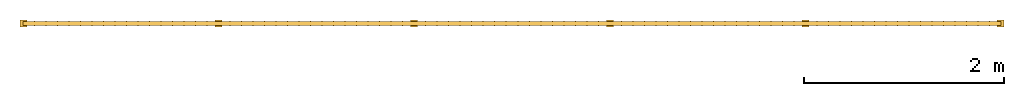
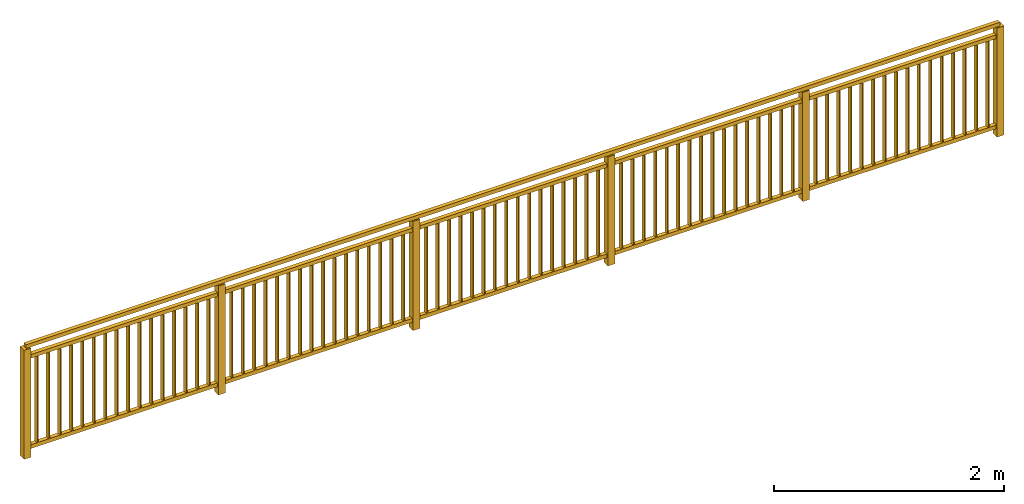
# Not in any storey: 1 railing.
"""IFC4 model written with IfcOpenShell, lengths in metres."""

from ifc_helpers import new_model, entity, si_unit, converted_unit, derived_unit, direction, frame, frame_2d, origin, place, context, subcontext, project, spatial, rectangle, extrude, material, element, save


model = new_model("IFC4")

# Units and contexts
model_context = context("Model", 3, precision=1e-05, world=origin(), true_north=direction((6.12303176911189e-17, 1.0)))
body_context = subcontext(model_context, "Body", "Model", "MODEL_VIEW")
ifc_project = project(units=[si_unit("LENGTHUNIT", "METRE"), si_unit("AREAUNIT", "SQUARE_METRE"), si_unit("VOLUMEUNIT", "CUBIC_METRE"), converted_unit("PLANEANGLEUNIT", "DEGREE", entity("IfcRatioMeasure", 0.0174532925199433), si_unit("PLANEANGLEUNIT", "RADIAN"), dimensions=[0, 0, 0, 0, 0, 0, 0]), si_unit("MASSUNIT", "GRAM", prefix="KILO"), derived_unit("MASSDENSITYUNIT", [(si_unit("MASSUNIT", "GRAM", prefix="KILO"), 1), (si_unit("LENGTHUNIT", "METRE"), -3)]), derived_unit("MOMENTOFINERTIAUNIT", [(si_unit("LENGTHUNIT", "METRE"), 4)]), si_unit("TIMEUNIT", "SECOND"), si_unit("FREQUENCYUNIT", "HERTZ"), si_unit("THERMODYNAMICTEMPERATUREUNIT", "DEGREE_CELSIUS"), derived_unit("THERMALTRANSMITTANCEUNIT", [(si_unit("MASSUNIT", "GRAM", prefix="KILO"), 1), (si_unit("THERMODYNAMICTEMPERATUREUNIT", "KELVIN"), -1), (si_unit("TIMEUNIT", "SECOND"), -3)]), derived_unit("VOLUMETRICFLOWRATEUNIT", [(si_unit("LENGTHUNIT", "METRE"), 3), (si_unit("TIMEUNIT", "SECOND"), -1)]), si_unit("ELECTRICCURRENTUNIT", "AMPERE"), si_unit("ELECTRICVOLTAGEUNIT", "VOLT"), si_unit("POWERUNIT", "WATT"), si_unit("FORCEUNIT", "NEWTON", prefix="KILO"), si_unit("ILLUMINANCEUNIT", "LUX"), si_unit("LUMINOUSFLUXUNIT", "LUMEN"), si_unit("LUMINOUSINTENSITYUNIT", "CANDELA"), derived_unit("USERDEFINED", [(si_unit("MASSUNIT", "GRAM", prefix="KILO"), -1), (si_unit("LENGTHUNIT", "METRE"), -2), (si_unit("TIMEUNIT", "SECOND"), 3), (si_unit("LUMINOUSFLUXUNIT", "LUMEN"), 1)]), derived_unit("LINEARVELOCITYUNIT", [(si_unit("LENGTHUNIT", "METRE"), 1), (si_unit("TIMEUNIT", "SECOND"), -1)]), si_unit("PRESSUREUNIT", "PASCAL"), derived_unit("USERDEFINED", [(si_unit("LENGTHUNIT", "METRE"), -2), (si_unit("MASSUNIT", "GRAM", prefix="KILO"), 1), (si_unit("TIMEUNIT", "SECOND"), -2)]), derived_unit("LINEARFORCEUNIT", [(si_unit("MASSUNIT", "GRAM", prefix="KILO"), 1), (si_unit("LENGTHUNIT", "METRE"), 1), (si_unit("TIMEUNIT", "SECOND"), -2), (si_unit("LENGTHUNIT", "METRE"), -1)]), derived_unit("PLANARFORCEUNIT", [(si_unit("MASSUNIT", "GRAM", prefix="KILO"), 1), (si_unit("LENGTHUNIT", "METRE"), 1), (si_unit("TIMEUNIT", "SECOND"), -2), (si_unit("LENGTHUNIT", "METRE"), -2)])], contexts=[model_context])

# Site
site_placement = place(None, origin())
site = spatial("IfcSite", under=ifc_project, at=site_placement, CompositionType="ELEMENT")

# Railing
ifc_material = material(Name="Kunststoff - grau 70-70-70", Category="Kunststoff")
railing_placement = place(site_placement, frame((-2.35917445388067, -3.01742114403174, 0.0)))
element("IfcRailing", 1, at=railing_placement, inside=site, material=ifc_material, PredefinedType="NOTDEFINED", context=body_context, shape_type="SweptSolid", body=[
    extrude(rectangle(XDim=0.00999999999999989, YDim=0.05, at=frame_2d((1.08290112987852e-15, -2.70616862252382e-16), x_axis=(1.0, 0.0))), frame((9.71470588235294, 0.0350000000000007, 0.12)), (0.0, 0.0, 1.0), 0.92),
    extrude(rectangle(XDim=0.00999999999999989, YDim=0.05, at=frame_2d((0.0, 2.70616862252382e-16), x_axis=(1.0, 0.0))), frame((9.59941176470589, 0.0350000000000012, 0.12)), (0.0, 0.0, 1.0), 0.92),
    extrude(rectangle(XDim=0.00999999999999989, YDim=0.05, at=frame_2d((-1.08290112987852e-15, -2.70616862252382e-16), x_axis=(1.0, 0.0))), frame((9.48411764705883, 0.0350000000000018, 0.12)), (0.0, 0.0, 1.0), 0.92),
    extrude(rectangle(XDim=0.00999999999999989, YDim=0.05, at=frame_2d((-1.08290112987852e-15, 2.70616862252382e-16), x_axis=(1.0, 0.0))), frame((9.36882352941177, 0.0350000000000023, 0.12)), (0.0, 0.0, 1.0), 0.92),
    extrude(rectangle(XDim=0.00999999999999989, YDim=0.05, at=frame_2d((0.0, -2.70616862252382e-16), x_axis=(1.0, 0.0))), frame((9.25352941176471, 0.0350000000000029, 0.12)), (0.0, 0.0, 1.0), 0.92),
    extrude(rectangle(XDim=0.00999999999999989, YDim=0.05, at=frame_2d((0.0, 2.70616862252382e-16), x_axis=(1.0, 0.0))), frame((9.13823529411765, 0.0350000000000034, 0.12)), (0.0, 0.0, 1.0), 0.92),
    extrude(rectangle(XDim=0.00999999999999989, YDim=0.05, at=frame_2d((1.08290112987852e-15, -2.70616862252382e-16), x_axis=(1.0, 0.0))), frame((9.02294117647059, 0.035000000000004, 0.12)), (0.0, 0.0, 1.0), 0.92),
    extrude(rectangle(XDim=0.00999999999999989, YDim=0.05, at=frame_2d((0.0, 2.70616862252382e-16), x_axis=(1.0, 0.0))), frame((8.90764705882353, 0.0350000000000045, 0.12)), (0.0, 0.0, 1.0), 0.92),
    extrude(rectangle(XDim=0.00999999999999989, YDim=0.05, at=frame_2d((0.0, -2.70616862252382e-16), x_axis=(1.0, 0.0))), frame((8.79235294117647, 0.035000000000005, 0.12)), (0.0, 0.0, 1.0), 0.92),
    extrude(rectangle(XDim=0.00999999999999989, YDim=0.05, at=frame_2d((0.0, -2.70616862252382e-16), x_axis=(1.0, 0.0))), frame((8.67705882352941, 0.035000000000005, 0.12)), (0.0, 0.0, 1.0), 0.92),
    extrude(rectangle(XDim=0.00999999999999989, YDim=0.05, at=frame_2d((0.0, 2.70616862252382e-16), x_axis=(1.0, 0.0))), frame((8.56176470588236, 0.0350000000000056, 0.12)), (0.0, 0.0, 1.0), 0.92),
    extrude(rectangle(XDim=0.00999999999999989, YDim=0.05, at=frame_2d((0.0, -2.70616862252382e-16), x_axis=(1.0, 0.0))), frame((8.4464705882353, 0.0350000000000061, 0.12)), (0.0, 0.0, 1.0), 0.92),
    extrude(rectangle(XDim=0.00999999999999989, YDim=0.05, at=frame_2d((0.0, 2.70616862252382e-16), x_axis=(1.0, 0.0))), frame((8.33117647058824, 0.0350000000000067, 0.12)), (0.0, 0.0, 1.0), 0.92),
    extrude(rectangle(XDim=0.00999999999999989, YDim=0.05, at=frame_2d((0.0, -2.70616862252382e-16), x_axis=(1.0, 0.0))), frame((8.21588235294118, 0.0350000000000072, 0.12)), (0.0, 0.0, 1.0), 0.92),
    extrude(rectangle(XDim=0.00999999999999989, YDim=0.05, at=frame_2d((0.0, 2.70616862252382e-16), x_axis=(1.0, 0.0))), frame((8.10058823529412, 0.0350000000000077, 0.12)), (0.0, 0.0, 1.0), 0.92),
    extrude(rectangle(XDim=0.00999999999999989, YDim=0.05, at=frame_2d((0.0, -2.70616862252382e-16), x_axis=(1.0, 0.0))), frame((7.98529411764706, 0.0350000000000083, 0.12)), (0.0, 0.0, 1.0), 0.92),
    extrude(rectangle(XDim=0.0699999999999992, YDim=0.0699999999999998, at=frame_2d((0.0, 2.70616862252382e-16), x_axis=(1.0, 0.0))), frame((7.87, 0.0350000000000088, 0.0)), (0.0, 0.0, 1.0), 1.16),
    extrude(rectangle(XDim=0.00999999999999989, YDim=0.05, at=frame_2d((0.0, -2.70616862252382e-16), x_axis=(1.0, 0.0))), frame((7.75470588235294, 0.0350000000000094, 0.12)), (0.0, 0.0, 1.0), 0.92),
    extrude(rectangle(XDim=0.00999999999999989, YDim=0.05, at=frame_2d((0.0, -2.70616862252382e-16), x_axis=(1.0, 0.0))), frame((7.63941176470589, 0.0350000000000094, 0.12)), (0.0, 0.0, 1.0), 0.92),
    extrude(rectangle(XDim=0.00999999999999989, YDim=0.05, at=frame_2d((0.0, 2.70616862252382e-16), x_axis=(1.0, 0.0))), frame((7.52411764705883, 0.0350000000000099, 0.12)), (0.0, 0.0, 1.0), 0.92),
    extrude(rectangle(XDim=0.00999999999999989, YDim=0.05, at=frame_2d((0.0, -2.70616862252382e-16), x_axis=(1.0, 0.0))), frame((7.40882352941177, 0.0350000000000105, 0.12)), (0.0, 0.0, 1.0), 0.92),
    extrude(rectangle(XDim=0.00999999999999989, YDim=0.05, at=frame_2d((0.0, 2.70616862252382e-16), x_axis=(1.0, 0.0))), frame((7.29352941176471, 0.035000000000011, 0.12)), (0.0, 0.0, 1.0), 0.92),
    extrude(rectangle(XDim=0.00999999999999989, YDim=0.05, at=frame_2d((0.0, -2.70616862252382e-16), x_axis=(1.0, 0.0))), frame((7.17823529411765, 0.0350000000000115, 0.12)), (0.0, 0.0, 1.0), 0.92),
    extrude(rectangle(XDim=0.00999999999999989, YDim=0.05, at=frame_2d((0.0, 2.70616862252382e-16), x_axis=(1.0, 0.0))), frame((7.06294117647059, 0.0350000000000121, 0.12)), (0.0, 0.0, 1.0), 0.92),
    extrude(rectangle(XDim=0.00999999999999989, YDim=0.05, at=frame_2d((0.0, -2.70616862252382e-16), x_axis=(1.0, 0.0))), frame((6.94764705882353, 0.0350000000000126, 0.12)), (0.0, 0.0, 1.0), 0.92),
    extrude(rectangle(XDim=0.00999999999999989, YDim=0.05, at=frame_2d((0.0, 2.70616862252382e-16), x_axis=(1.0, 0.0))), frame((6.83235294117647, 0.0350000000000132, 0.12)), (0.0, 0.0, 1.0), 0.92),
    extrude(rectangle(XDim=0.00999999999999989, YDim=0.05, at=frame_2d((0.0, -2.70616862252382e-16), x_axis=(1.0, 0.0))), frame((6.71705882352941, 0.0350000000000137, 0.12)), (0.0, 0.0, 1.0), 0.92),
    extrude(rectangle(XDim=0.00999999999999989, YDim=0.05, at=frame_2d((0.0, -2.70616862252382e-16), x_axis=(1.0, 0.0))), frame((6.60176470588236, 0.0350000000000137, 0.12)), (0.0, 0.0, 1.0), 0.92),
    extrude(rectangle(XDim=0.00999999999999989, YDim=0.05, at=frame_2d((0.0, 2.70616862252382e-16), x_axis=(1.0, 0.0))), frame((6.4864705882353, 0.0350000000000142, 0.12)), (0.0, 0.0, 1.0), 0.92),
    extrude(rectangle(XDim=0.00999999999999989, YDim=0.05, at=frame_2d((0.0, -2.70616862252382e-16), x_axis=(1.0, 0.0))), frame((6.37117647058824, 0.0350000000000148, 0.12)), (0.0, 0.0, 1.0), 0.92),
    extrude(rectangle(XDim=0.00999999999999989, YDim=0.05, at=frame_2d((0.0, 2.70616862252382e-16), x_axis=(1.0, 0.0))), frame((6.25588235294118, 0.0350000000000153, 0.12)), (0.0, 0.0, 1.0), 0.92),
    extrude(rectangle(XDim=0.00999999999999989, YDim=0.05, at=frame_2d((0.0, -2.70616862252382e-16), x_axis=(1.0, 0.0))), frame((6.14058823529412, 0.0350000000000159, 0.12)), (0.0, 0.0, 1.0), 0.92),
    extrude(rectangle(XDim=0.00999999999999989, YDim=0.05, at=frame_2d((0.0, 2.70616862252382e-16), x_axis=(1.0, 0.0))), frame((6.02529411764706, 0.0350000000000164, 0.12)), (0.0, 0.0, 1.0), 0.92),
    extrude(rectangle(XDim=0.0700000000000009, YDim=0.0699999999999998, at=frame_2d((-2.70616862252382e-16, -2.70616862252382e-16), x_axis=(1.0, 0.0))), frame((5.91, 0.0350000000000175, 0.0)), (0.0, 0.0, 1.0), 1.16),
    extrude(rectangle(XDim=0.00999999999999989, YDim=0.05, at=frame_2d((0.0, 2.70616862252382e-16), x_axis=(1.0, 0.0))), frame((5.79470588235294, 0.0350000000000175, 0.12)), (0.0, 0.0, 1.0), 0.92),
    extrude(rectangle(XDim=0.00999999999999989, YDim=0.05, at=frame_2d((0.0, -2.70616862252382e-16), x_axis=(1.0, 0.0))), frame((5.67941176470589, 0.035000000000018, 0.12)), (0.0, 0.0, 1.0), 0.92),
    extrude(rectangle(XDim=0.00999999999999989, YDim=0.05, at=frame_2d((0.0, -2.70616862252382e-16), x_axis=(1.0, 0.0))), frame((5.56411764705883, 0.035000000000018, 0.12)), (0.0, 0.0, 1.0), 0.92),
    extrude(rectangle(XDim=0.00999999999999989, YDim=0.05, at=frame_2d((0.0, 2.70616862252382e-16), x_axis=(1.0, 0.0))), frame((5.44882352941177, 0.0350000000000186, 0.12)), (0.0, 0.0, 1.0), 0.92),
    extrude(rectangle(XDim=0.00999999999999989, YDim=0.05, at=frame_2d((0.0, -2.70616862252382e-16), x_axis=(1.0, 0.0))), frame((5.33352941176471, 0.0350000000000191, 0.12)), (0.0, 0.0, 1.0), 0.92),
    extrude(rectangle(XDim=0.00999999999999989, YDim=0.05, at=frame_2d((0.0, 2.70616862252382e-16), x_axis=(1.0, 0.0))), frame((5.21823529411765, 0.0350000000000197, 0.12)), (0.0, 0.0, 1.0), 0.92),
    extrude(rectangle(XDim=0.00999999999999989, YDim=0.05, at=frame_2d((0.0, -2.70616862252382e-16), x_axis=(1.0, 0.0))), frame((5.10294117647059, 0.0350000000000202, 0.12)), (0.0, 0.0, 1.0), 0.92),
    extrude(rectangle(XDim=0.00999999999999989, YDim=0.05, at=frame_2d((0.0, 2.70616862252382e-16), x_axis=(1.0, 0.0))), frame((4.98764705882353, 0.0350000000000207, 0.12)), (0.0, 0.0, 1.0), 0.92),
    extrude(rectangle(XDim=0.00999999999999989, YDim=0.05, at=frame_2d((0.0, -2.70616862252382e-16), x_axis=(1.0, 0.0))), frame((4.87235294117647, 0.0350000000000213, 0.12)), (0.0, 0.0, 1.0), 0.92),
    extrude(rectangle(XDim=0.0100000000000002, YDim=0.05, at=frame_2d((-1.35308431126191e-16, 2.70616862252382e-16), x_axis=(1.0, 0.0))), frame((4.75705882352941, 0.0350000000000218, 0.12)), (0.0, 0.0, 1.0), 0.92),
    extrude(rectangle(XDim=0.0100000000000002, YDim=0.05, at=frame_2d((-1.35742111995185e-16, -2.70616862252382e-16), x_axis=(1.0, 0.0))), frame((4.64176470588236, 0.0350000000000224, 0.12)), (0.0, 0.0, 1.0), 0.92),
    extrude(rectangle(XDim=0.0100000000000002, YDim=0.05, at=frame_2d((-1.35742111995185e-16, -2.70616862252382e-16), x_axis=(1.0, 0.0))), frame((4.5264705882353, 0.0350000000000224, 0.12)), (0.0, 0.0, 1.0), 0.92),
    extrude(rectangle(XDim=0.0100000000000002, YDim=0.05, at=frame_2d((-1.35308431126191e-16, 2.70616862252382e-16), x_axis=(1.0, 0.0))), frame((4.41117647058824, 0.0350000000000229, 0.12)), (0.0, 0.0, 1.0), 0.92),
    extrude(rectangle(XDim=0.0100000000000002, YDim=0.05, at=frame_2d((1.35742111995185e-16, -2.70616862252382e-16), x_axis=(1.0, 0.0))), frame((4.29588235294118, 0.0350000000000235, 0.12)), (0.0, 0.0, 1.0), 0.92),
    extrude(rectangle(XDim=0.0100000000000002, YDim=0.05, at=frame_2d((-1.35308431126191e-16, 2.70616862252382e-16), x_axis=(1.0, 0.0))), frame((4.18058823529412, 0.035000000000024, 0.12)), (0.0, 0.0, 1.0), 0.92),
    extrude(rectangle(XDim=0.0100000000000002, YDim=0.05, at=frame_2d((-1.35742111995185e-16, -2.70616862252382e-16), x_axis=(1.0, 0.0))), frame((4.06529411764706, 0.0350000000000245, 0.12)), (0.0, 0.0, 1.0), 0.92),
    extrude(rectangle(XDim=0.0699999999999995, YDim=0.0699999999999998, at=frame_2d((1.35308431126191e-16, 2.70616862252382e-16), x_axis=(1.0, 0.0))), frame((3.95, 0.0350000000000251, 0.0)), (0.0, 0.0, 1.0), 1.16),
    extrude(rectangle(XDim=0.0100000000000002, YDim=0.05, at=frame_2d((-1.35742111995185e-16, -2.70616862252382e-16), x_axis=(1.0, 0.0))), frame((3.83470588235294, 0.0350000000000256, 0.12)), (0.0, 0.0, 1.0), 0.92),
    extrude(rectangle(XDim=0.0100000000000002, YDim=0.05, at=frame_2d((-1.35308431126191e-16, 2.70616862252382e-16), x_axis=(1.0, 0.0))), frame((3.71941176470588, 0.0350000000000262, 0.12)), (0.0, 0.0, 1.0), 0.92),
    extrude(rectangle(XDim=0.0100000000000002, YDim=0.05, at=frame_2d((-1.35742111995185e-16, -2.70616862252382e-16), x_axis=(1.0, 0.0))), frame((3.60411764705882, 0.0350000000000267, 0.12)), (0.0, 0.0, 1.0), 0.92),
    extrude(rectangle(XDim=0.00999999999999989, YDim=0.05, at=frame_2d((0.0, -2.70616862252382e-16), x_axis=(1.0, 0.0))), frame((3.48882352941177, 0.0350000000000267, 0.12)), (0.0, 0.0, 1.0), 0.92),
    extrude(rectangle(XDim=0.00999999999999989, YDim=0.05, at=frame_2d((0.0, 2.70616862252382e-16), x_axis=(1.0, 0.0))), frame((3.37352941176471, 0.0350000000000272, 0.12)), (0.0, 0.0, 1.0), 0.92),
    extrude(rectangle(XDim=0.00999999999999989, YDim=0.05, at=frame_2d((1.35742111995185e-16, -2.70616862252382e-16), x_axis=(1.0, 0.0))), frame((3.25823529411765, 0.0350000000000278, 0.12)), (0.0, 0.0, 1.0), 0.92),
    extrude(rectangle(XDim=0.00999999999999989, YDim=0.05, at=frame_2d((0.0, 2.70616862252382e-16), x_axis=(1.0, 0.0))), frame((3.14294117647059, 0.0350000000000283, 0.12)), (0.0, 0.0, 1.0), 0.92),
    extrude(rectangle(XDim=0.00999999999999989, YDim=0.05, at=frame_2d((0.0, -2.70616862252382e-16), x_axis=(1.0, 0.0))), frame((3.02764705882353, 0.0350000000000289, 0.12)), (0.0, 0.0, 1.0), 0.92),
    extrude(rectangle(XDim=0.00999999999999996, YDim=0.05, at=frame_2d((-3.38271077815477e-17, 2.70616862252382e-16), x_axis=(1.0, 0.0))), frame((2.91235294117647, 0.0350000000000294, 0.12)), (0.0, 0.0, 1.0), 0.92),
    extrude(rectangle(XDim=0.00999999999999996, YDim=0.05, at=frame_2d((-3.38271077815477e-17, -2.70616862252382e-16), x_axis=(1.0, 0.0))), frame((2.79705882352941, 0.0350000000000299, 0.12)), (0.0, 0.0, 1.0), 0.92),
    extrude(rectangle(XDim=0.00999999999999996, YDim=0.05, at=frame_2d((-3.38271077815477e-17, 2.70616862252382e-16), x_axis=(1.0, 0.0))), frame((2.68176470588235, 0.0350000000000305, 0.12)), (0.0, 0.0, 1.0), 0.92),
    extrude(rectangle(XDim=0.01, YDim=0.05, at=frame_2d((0.0, -2.70616862252382e-16), x_axis=(1.0, 0.0))), frame((2.5664705882353, 0.035000000000031, 0.12)), (0.0, 0.0, 1.0), 0.92),
    extrude(rectangle(XDim=0.01, YDim=0.05, at=frame_2d((0.0, -2.70616862252382e-16), x_axis=(1.0, 0.0))), frame((2.45117647058824, 0.035000000000031, 0.12)), (0.0, 0.0, 1.0), 0.92),
    extrude(rectangle(XDim=0.01, YDim=0.05, at=frame_2d((2.16840434497101e-18, 2.70616862252382e-16), x_axis=(1.0, 0.0))), frame((2.33588235294118, 0.0350000000000316, 0.12)), (0.0, 0.0, 1.0), 0.92),
    extrude(rectangle(XDim=0.01, YDim=0.05, at=frame_2d((-1.69135538907739e-17, -2.70616862252382e-16), x_axis=(1.0, 0.0))), frame((2.22058823529412, 0.0350000000000321, 0.12)), (0.0, 0.0, 1.0), 0.92),
    extrude(rectangle(XDim=0.01, YDim=0.05, at=frame_2d((0.0, 2.70616862252382e-16), x_axis=(1.0, 0.0))), frame((2.10529411764706, 0.0350000000000327, 0.12)), (0.0, 0.0, 1.0), 0.92),
    extrude(rectangle(XDim=0.0700000000000001, YDim=0.0699999999999998, at=frame_2d((0.0, 2.70616862252382e-16), x_axis=(1.0, 0.0))), frame((1.99, 0.0350000000000332, 0.0)), (0.0, 0.0, 1.0), 1.16),
    extrude(rectangle(XDim=0.00999999999999996, YDim=0.05, at=frame_2d((-3.38271077815477e-17, 2.70616862252382e-16), x_axis=(1.0, 0.0))), frame((1.87470588235294, 0.0350000000000337, 0.12)), (0.0, 0.0, 1.0), 0.92),
    extrude(rectangle(XDim=0.00999999999999996, YDim=0.05, at=frame_2d((3.38271077815477e-17, -2.70616862252382e-16), x_axis=(1.0, 0.0))), frame((1.75941176470588, 0.0350000000000343, 0.12)), (0.0, 0.0, 1.0), 0.92),
    extrude(rectangle(XDim=0.00999999999999989, YDim=0.05, at=frame_2d((0.0, 2.70616862252382e-16), x_axis=(1.0, 0.0))), frame((1.64411764705882, 0.0350000000000348, 0.12)), (0.0, 0.0, 1.0), 0.92),
    extrude(rectangle(XDim=0.00999999999999989, YDim=0.05, at=frame_2d((0.0, -2.70616862252382e-16), x_axis=(1.0, 0.0))), frame((1.52882352941177, 0.0350000000000354, 0.12)), (0.0, 0.0, 1.0), 0.92),
    extrude(rectangle(XDim=0.00999999999999989, YDim=0.05, at=frame_2d((-1.35742111995185e-16, -2.70616862252382e-16), x_axis=(1.0, 0.0))), frame((1.41352941176471, 0.0350000000000354, 0.12)), (0.0, 0.0, 1.0), 0.92),
    extrude(rectangle(XDim=0.00999999999999989, YDim=0.05, at=frame_2d((0.0, 2.70616862252382e-16), x_axis=(1.0, 0.0))), frame((1.29823529411765, 0.0350000000000359, 0.12)), (0.0, 0.0, 1.0), 0.92),
    extrude(rectangle(XDim=0.00999999999999989, YDim=0.05, at=frame_2d((0.0, -2.70616862252382e-16), x_axis=(1.0, 0.0))), frame((1.18294117647059, 0.0350000000000364, 0.12)), (0.0, 0.0, 1.0), 0.92),
    extrude(rectangle(XDim=0.0100000000000002, YDim=0.05, at=frame_2d((-1.35308431126191e-16, 2.70616862252382e-16), x_axis=(1.0, 0.0))), frame((1.06764705882353, 0.035000000000037, 0.12)), (0.0, 0.0, 1.0), 0.92),
    extrude(rectangle(XDim=0.0100000000000002, YDim=0.05, at=frame_2d((-1.35742111995185e-16, -2.70616862252382e-16), x_axis=(1.0, 0.0))), frame((0.952352941176471, 0.0350000000000375, 0.12)), (0.0, 0.0, 1.0), 0.92),
    extrude(rectangle(XDim=0.0100000000000002, YDim=0.05, at=frame_2d((-1.35308431126191e-16, 2.70616862252382e-16), x_axis=(1.0, 0.0))), frame((0.837058823529412, 0.0350000000000381, 0.12)), (0.0, 0.0, 1.0), 0.92),
    extrude(rectangle(XDim=0.0100000000000002, YDim=0.05, at=frame_2d((-1.35742111995185e-16, -2.70616862252382e-16), x_axis=(1.0, 0.0))), frame((0.721764705882354, 0.0350000000000386, 0.12)), (0.0, 0.0, 1.0), 0.92),
    extrude(rectangle(XDim=0.0100000000000002, YDim=0.05, at=frame_2d((-1.35308431126191e-16, 2.70616862252382e-16), x_axis=(1.0, 0.0))), frame((0.606470588235295, 0.0350000000000391, 0.12)), (0.0, 0.0, 1.0), 0.92),
    extrude(rectangle(XDim=0.0100000000000002, YDim=0.05, at=frame_2d((-1.35742111995185e-16, -2.70616862252382e-16), x_axis=(1.0, 0.0))), frame((0.491176470588236, 0.0350000000000397, 0.12)), (0.0, 0.0, 1.0), 0.92),
    extrude(rectangle(XDim=0.0100000000000002, YDim=0.05, at=frame_2d((-1.35742111995185e-16, -2.70616862252382e-16), x_axis=(1.0, 0.0))), frame((0.375882352941177, 0.0350000000000397, 0.12)), (0.0, 0.0, 1.0), 0.92),
    extrude(rectangle(XDim=0.0100000000000002, YDim=0.05, at=frame_2d((-1.35308431126191e-16, 2.70616862252382e-16), x_axis=(1.0, 0.0))), frame((0.260588235294118, 0.0350000000000402, 0.12)), (0.0, 0.0, 1.0), 0.92),
    extrude(rectangle(XDim=0.0100000000000002, YDim=0.05, at=frame_2d((-1.35742111995185e-16, -2.70616862252382e-16), x_axis=(1.0, 0.0))), frame((0.145294117647059, 0.0350000000000408, 0.12)), (0.0, 0.0, 1.0), 0.92),
    extrude(rectangle(XDim=0.0699999999999992, YDim=0.0699999999999998, at=frame_2d((0.0, 2.70616862252382e-16), x_axis=(1.0, 0.0))), frame((9.82500000000001, 0.0350000000000007, 0.0)), (0.0, 0.0, 1.0), 1.16),
    extrude(rectangle(XDim=0.0699999999999995, YDim=0.0699999999999998, at=frame_2d((1.35308431126191e-16, 2.70616862252382e-16), x_axis=(1.0, 0.0))), frame((0.0350000000000002, 0.0350000000000413, 0.0)), (0.0, 0.0, 1.0), 1.16),
    extrude(rectangle(XDim=9.8, YDim=0.0400000000000001, at=frame_2d((0.0, -2.70616862252382e-16), x_axis=(1.0, 0.0))), frame((4.93, 0.0350000000000213, 1.16)), (0.0, 0.0, 1.0), 0.04),
    extrude(rectangle(XDim=9.8, YDim=0.0400000000000001, at=frame_2d((0.0, -2.70616862252382e-16), x_axis=(1.0, 0.0))), frame((4.93, 0.0350000000000213, 1.04)), (0.0, 0.0, 1.0), 0.04),
    extrude(rectangle(XDim=9.8, YDim=0.0400000000000001, at=frame_2d((0.0, -2.70616862252382e-16), x_axis=(1.0, 0.0))), frame((4.93, 0.0350000000000213, 0.08)), (0.0, 0.0, 1.0), 0.04),
])

save(model, "model.ifc")
